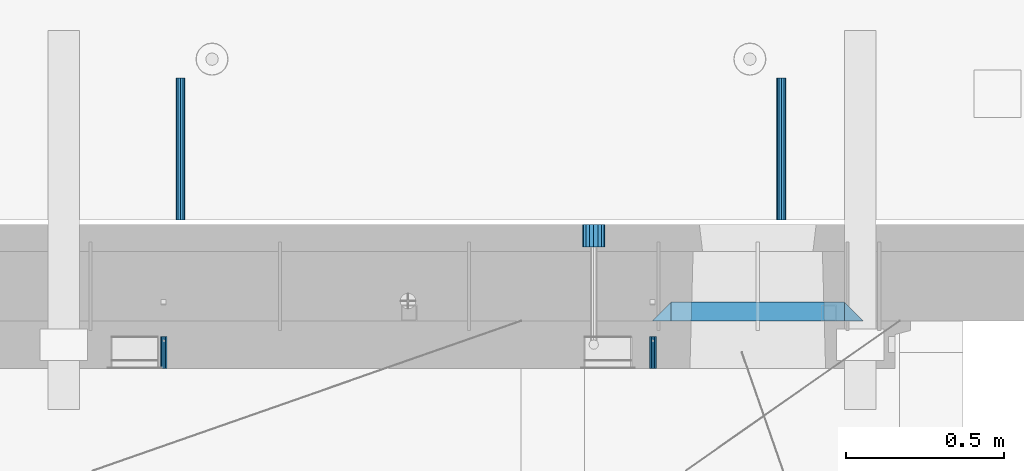
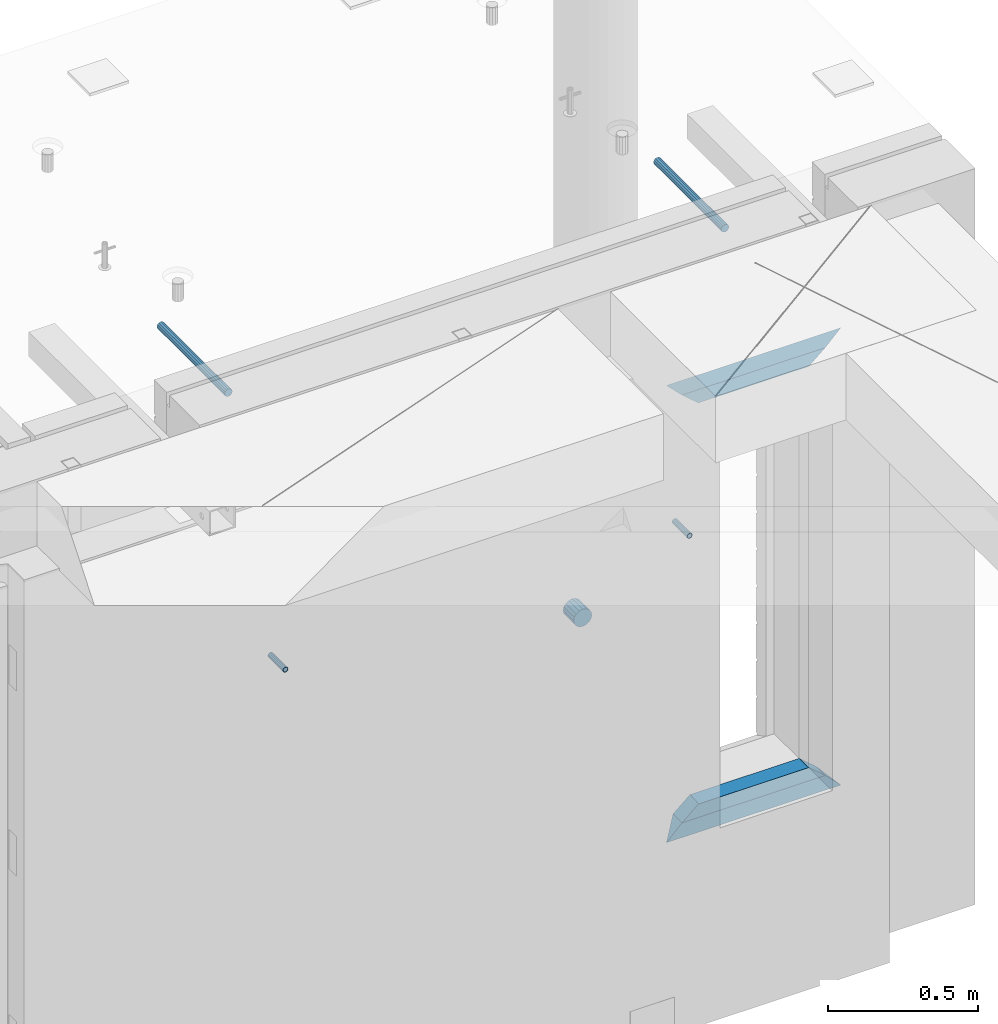
# One storey, part 143 of 309: 9 beams, 6 elements without a shape of their own.
"""IFC2X3 building model written with IfcOpenShell, lengths in millimetres."""

from ifc_helpers import new_model, si_unit, frame, origin_with_axes, place, context, subcontext, project, spatial, faceted_brep, material, type_object, element, aggregate, save


model = new_model("IFC2X3")

# Units and contexts
model_context = context("Model", 3, precision=1e-05, world=origin_with_axes())
body_context = subcontext(model_context, "Body", "Model", "MODEL_VIEW")
ifc_project = project(units=[si_unit("LENGTHUNIT", "METRE", prefix="MILLI"), si_unit("AREAUNIT", "SQUARE_METRE"), si_unit("VOLUMEUNIT", "CUBIC_METRE"), si_unit("MASSUNIT", "GRAM", prefix="KILO"), si_unit("TIMEUNIT", "SECOND"), si_unit("PLANEANGLEUNIT", "RADIAN"), si_unit("SOLIDANGLEUNIT", "STERADIAN"), si_unit("THERMODYNAMICTEMPERATUREUNIT", "DEGREE_CELSIUS"), si_unit("LUMINOUSINTENSITYUNIT", "LUMEN")], contexts=[model_context])

# Site, building, storey
site_placement = place(None, origin_with_axes())
site = spatial("IfcSite", under=ifc_project, at=site_placement, CompositionType="ELEMENT")
building_placement = place(site_placement, origin_with_axes())
building = spatial("IfcBuilding", under=site, at=building_placement, CompositionType="ELEMENT")
storey_placement = place(building_placement, origin_with_axes())
storey = spatial("IfcBuildingStorey", under=building, at=storey_placement, Name="7", CompositionType="ELEMENT", Elevation=0.0)

# Assemblies, beams
assembly_1_placement = place(storey_placement, origin_with_axes())
assembly_1 = element("IfcElementAssembly", 1, at=assembly_1_placement, inside=storey, AssemblyPlace="NOTDEFINED", PredefinedType="REINFORCEMENT_UNIT")
assembly_2_placement = place(assembly_1_placement, origin_with_axes())
assembly_2 = element("IfcElementAssembly", 2, at=assembly_2_placement, Name="Steel Assembly", AssemblyPlace="NOTDEFINED", PredefinedType="RIGID_FRAME")
ifc_material_1 = material(Name="STEEL/Steel_Undefined")
beam_type_1 = type_object("IfcBeamType", PredefinedType="NOTDEFINED")
beam_1_placement = place(assembly_2_placement, frame((34077.8782931989, 20429.9951872276, 101755.0), z_axis=(-1.0, 3.00000001838171e-08, 0.0), x_axis=(0.0, 1.0, 0.0)))
beam_1 = element("IfcBeam", 3, at=beam_1_placement, type_object=beam_type_1, material=ifc_material_1, Name="M16", context=body_context, shape_type="Brep", body=[
    faceted_brep([(0.0, -8.49999999999272, -1.45519152283669e-11), (0.0, -7.36121593215648, 4.24999999998545), (100.000000000262, -7.36121593215648, 4.24999999998545), (100.000000000262, -8.49999999999272, -1.45519152283669e-11), (0.0, -4.24999999998545, 7.36121593216376), (100.000000000262, -4.24999999998545, 7.36121593216376), (0.0, 1.45519152283669e-11, 8.49999999998545), (100.000000000262, 1.45519152283669e-11, 8.49999999998545), (0.0, 4.25000000001455, 7.36121593216376), (100.000000000262, 4.25000000001455, 7.36121593216376), (0.0, 7.36121593217104, 4.24999999998545), (100.000000000262, 7.36121593217104, 4.24999999998545), (0.0, 8.50000000000728, 0.0), (100.000000000262, 8.50000000000728, 0.0), (0.0, 7.36121593217104, -4.25000000001455), (100.000000000262, 7.36121593217104, -4.25000000001455), (0.0, 4.25000000000728, -7.36121593219286), (100.000000000262, 4.25000000000728, -7.36121593219286), (0.0, 7.27595761418343e-12, -8.5), (100.000000000262, 7.27595761418343e-12, -8.5), (0.0, -4.24999999999272, -7.36121593217831), (100.000000000262, -4.24999999999272, -7.36121593217831), (0.0, -7.36121593215648, -4.25), (100.000000000262, -7.36121593215648, -4.25), (0.0, -10.4999999999927, -1.45519152283669e-11), (0.0, -9.09326673972828, -5.25000000001455), (100.000000000262, -9.09326673972828, -5.25000000001455), (100.000000000262, -10.4999999999927, -1.45519152283669e-11), (0.0, -5.24999999998545, -9.09326673974283), (100.000000000262, -5.24999999998545, -9.09326673974283), (0.0, 7.27595761418343e-12, -10.5), (100.000000000262, 7.27595761418343e-12, -10.5), (0.0, 5.25000000001455, -9.09326673975738), (100.000000000262, 5.25000000001455, -9.09326673975738), (0.0, 9.09326673975011, -5.25000000001455), (100.000000000262, 9.09326673975011, -5.25000000001455), (0.0, 10.5000000000073, -1.45519152283669e-11), (100.000000000262, 10.5000000000073, -1.45519152283669e-11), (0.0, 9.09326673975011, 5.25), (100.000000000262, 9.09326673975011, 5.25), (0.0, 5.25000000000728, 9.09326673972828), (100.000000000262, 5.25000000000728, 9.09326673972828), (0.0, 1.45519152283669e-11, 10.4999999999854), (100.000000000262, 1.45519152283669e-11, 10.4999999999854), (0.0, -5.24999999999272, 9.09326673972828), (100.000000000262, -5.24999999999272, 9.09326673972828), (0.0, -9.09326673972828, 5.24999999998545), (100.000000000262, -9.09326673972828, 5.24999999998545)], [[[0, 1, 2, 3]], [[1, 4, 5, 2]], [[4, 6, 7, 5]], [[6, 8, 9, 7]], [[8, 10, 11, 9]], [[10, 12, 13, 11]], [[12, 14, 15, 13]], [[14, 16, 17, 15]], [[16, 18, 19, 17]], [[18, 20, 21, 19]], [[20, 22, 23, 21]], [[22, 0, 3, 23]], [[24, 25, 26, 27]], [[25, 28, 29, 26]], [[28, 30, 31, 29]], [[30, 32, 33, 31]], [[32, 34, 35, 33]], [[34, 36, 37, 35]], [[36, 38, 39, 37]], [[38, 40, 41, 39]], [[40, 42, 43, 41]], [[42, 44, 45, 43]], [[44, 46, 47, 45]], [[46, 24, 27, 47]], [[29, 31, 33, 35, 37, 39, 41, 43, 45, 47, 27, 26], [5, 7, 9, 11, 13, 15, 17, 19, 21, 23, 3, 2]], [[46, 44, 42, 40, 38, 36, 34, 32, 30, 28, 25, 24], [22, 20, 18, 16, 14, 12, 10, 8, 6, 4, 1, 0]]]),
])
aggregate(assembly_2, [beam_1])
assembly_3_placement = place(assembly_1_placement, origin_with_axes())
assembly_3 = element("IfcElementAssembly", 4, at=assembly_3_placement, Name="Steel Assembly", AssemblyPlace="NOTDEFINED", PredefinedType="RIGID_FRAME")
beam_2_placement = place(assembly_3_placement, frame((32527.3782931989, 20429.9951872276, 101755.0), z_axis=(-1.0, 3.00000001838171e-08, 0.0), x_axis=(0.0, 1.0, 0.0)))
beam_2 = element("IfcBeam", 5, at=beam_2_placement, type_object=beam_type_1, material=ifc_material_1, Name="M16", context=body_context, shape_type="Brep", body=[
    faceted_brep([(0.0, -8.49999999999272, -1.45519152283669e-11), (0.0, -7.36121593215648, 4.24999999998545), (100.000000000262, -7.36121593215648, 4.24999999998545), (100.000000000262, -8.49999999999272, -1.45519152283669e-11), (0.0, -4.24999999998545, 7.36121593216376), (100.000000000262, -4.24999999998545, 7.36121593216376), (0.0, 1.45519152283669e-11, 8.49999999998545), (100.000000000262, 1.45519152283669e-11, 8.49999999998545), (0.0, 4.25000000001455, 7.36121593216376), (100.000000000262, 4.25000000001455, 7.36121593216376), (0.0, 7.36121593217104, 4.24999999998545), (100.000000000262, 7.36121593217104, 4.24999999998545), (0.0, 8.50000000000728, 0.0), (100.000000000262, 8.50000000000728, 0.0), (0.0, 7.36121593217104, -4.25000000001455), (100.000000000262, 7.36121593217104, -4.25000000001455), (0.0, 4.25000000000728, -7.36121593219286), (100.000000000262, 4.25000000000728, -7.36121593219286), (0.0, 7.27595761418343e-12, -8.5), (100.000000000262, 7.27595761418343e-12, -8.5), (0.0, -4.24999999999272, -7.36121593217831), (100.000000000262, -4.24999999999272, -7.36121593217831), (0.0, -7.36121593215648, -4.25), (100.000000000262, -7.36121593215648, -4.25), (0.0, -10.4999999999927, -1.45519152283669e-11), (0.0, -9.09326673972828, -5.25000000001455), (100.000000000262, -9.09326673972828, -5.25000000001455), (100.000000000262, -10.4999999999927, -1.45519152283669e-11), (0.0, -5.24999999998545, -9.09326673974283), (100.000000000262, -5.24999999998545, -9.09326673974283), (0.0, 7.27595761418343e-12, -10.5), (100.000000000262, 7.27595761418343e-12, -10.5), (0.0, 5.25000000001455, -9.09326673975738), (100.000000000262, 5.25000000001455, -9.09326673975738), (0.0, 9.09326673975011, -5.25000000001455), (100.000000000262, 9.09326673975011, -5.25000000001455), (0.0, 10.5000000000073, -1.45519152283669e-11), (100.000000000262, 10.5000000000073, -1.45519152283669e-11), (0.0, 9.09326673975011, 5.25), (100.000000000262, 9.09326673975011, 5.25), (0.0, 5.25000000000728, 9.09326673972828), (100.000000000262, 5.25000000000728, 9.09326673972828), (0.0, 1.45519152283669e-11, 10.4999999999854), (100.000000000262, 1.45519152283669e-11, 10.4999999999854), (0.0, -5.24999999999272, 9.09326673972828), (100.000000000262, -5.24999999999272, 9.09326673972828), (0.0, -9.09326673972828, 5.24999999998545), (100.000000000262, -9.09326673972828, 5.24999999998545)], [[[0, 1, 2, 3]], [[1, 4, 5, 2]], [[4, 6, 7, 5]], [[6, 8, 9, 7]], [[8, 10, 11, 9]], [[10, 12, 13, 11]], [[12, 14, 15, 13]], [[14, 16, 17, 15]], [[16, 18, 19, 17]], [[18, 20, 21, 19]], [[20, 22, 23, 21]], [[22, 0, 3, 23]], [[24, 25, 26, 27]], [[25, 28, 29, 26]], [[28, 30, 31, 29]], [[30, 32, 33, 31]], [[32, 34, 35, 33]], [[34, 36, 37, 35]], [[36, 38, 39, 37]], [[38, 40, 41, 39]], [[40, 42, 43, 41]], [[42, 44, 45, 43]], [[44, 46, 47, 45]], [[46, 24, 27, 47]], [[29, 31, 33, 35, 37, 39, 41, 43, 45, 47, 27, 26], [5, 7, 9, 11, 13, 15, 17, 19, 21, 23, 3, 2]], [[46, 44, 42, 40, 38, 36, 34, 32, 30, 28, 25, 24], [22, 20, 18, 16, 14, 12, 10, 8, 6, 4, 1, 0]]]),
])
aggregate(assembly_3, [beam_2])
ifc_material_2 = material()
beam_type_2 = type_object("IfcBeamType", Name="D70", PredefinedType="NOTDEFINED")
beam_3_placement = place(assembly_1_placement, frame((33890.0, 20884.9951872276, 101255.0), z_axis=(0.0, 0.0, 1.0), x_axis=(0.0, -1.0, 0.0)))
beam_3 = element("IfcBeam", 6, at=beam_3_placement, type_object=beam_type_2, material=ifc_material_2, ObjectType="D70", context=body_context, shape_type="Brep", body=[
    faceted_brep([(0.0, -35.0, 0.0), (0.0, -32.3357836378964, -13.3939201327739), (70.0, -32.3357836378964, -13.3939201327739), (70.0, -35.0, 0.0), (0.0, -24.7487373415279, -24.7487373415352), (70.0, -24.7487373415279, -24.7487373415352), (0.0, -13.3939201327776, -32.3357836379), (70.0, -13.3939201327776, -32.3357836379), (0.0, 0.0, -35.0), (70.0, 0.0, -35.0), (0.0, 13.3939201327776, -32.3357836379), (70.0, 13.3939201327776, -32.3357836379), (0.0, 24.7487373415279, -24.7487373415352), (70.0, 24.7487373415279, -24.7487373415352), (0.0, 32.3357836378964, -13.3939201327739), (70.0, 32.3357836378964, -13.3939201327739), (0.0, 35.0, 0.0), (70.0, 35.0, 0.0), (0.0, 32.3357836378964, 13.3939201327739), (70.0, 32.3357836378964, 13.3939201327739), (0.0, 24.7487373415279, 24.7487373415352), (70.0, 24.7487373415279, 24.7487373415352), (0.0, 13.3939201327776, 32.3357836379), (70.0, 13.3939201327776, 32.3357836379), (0.0, 0.0, 35.0), (70.0, 0.0, 35.0), (0.0, -13.3939201327776, 32.3357836379), (70.0, -13.3939201327776, 32.3357836379), (0.0, -24.7487373415279, 24.7487373415352), (70.0, -24.7487373415279, 24.7487373415352), (0.0, -32.3357836378964, 13.3939201327739), (70.0, -32.3357836378964, 13.3939201327739)], [[[0, 1, 2, 3]], [[1, 4, 5, 2]], [[4, 6, 7, 5]], [[6, 8, 9, 7]], [[8, 10, 11, 9]], [[10, 12, 13, 11]], [[12, 14, 15, 13]], [[14, 16, 17, 15]], [[16, 18, 19, 17]], [[18, 20, 21, 19]], [[20, 22, 23, 21]], [[22, 24, 25, 23]], [[24, 26, 27, 25]], [[26, 28, 29, 27]], [[28, 30, 31, 29]], [[30, 0, 3, 31]], [[5, 7, 9, 11, 13, 15, 17, 19, 21, 23, 25, 27, 29, 31, 3, 2]], [[30, 28, 26, 24, 22, 20, 18, 16, 14, 12, 10, 8, 6, 4, 1, 0]]]),
])

assembly_4_placement = place(storey_placement, origin_with_axes())
assembly_4 = element("IfcElementAssembly", 7, at=assembly_4_placement, inside=storey, AssemblyPlace="NOTDEFINED", PredefinedType="REINFORCEMENT_UNIT")
assembly_5_placement = place(assembly_4_placement, origin_with_axes())
assembly_5 = element("IfcElementAssembly", 8, at=assembly_5_placement, Name="Steel Assembly", AssemblyPlace="NOTDEFINED", PredefinedType="RIGID_FRAME")
ifc_material_3 = material(Name="STEEL/S235JR")
beam_type_3 = type_object("IfcBeamType", Name="D30", PredefinedType="NOTDEFINED")
beam_4_placement = place(assembly_5_placement, frame((32579.9998567563, 20900.0253394533, 102575.0), z_axis=(0.0, 0.0, 1.0), x_axis=(0.0, 1.0, 0.0)))
beam_4 = element("IfcBeam", 9, at=beam_4_placement, type_object=beam_type_3, material=ifc_material_3, Name="Rd30", ObjectType="D30", context=body_context, shape_type="Brep", body=[
    faceted_brep([(0.0, -15.0, 0.0), (0.0, -12.9903810567666, -7.5), (450.0, -12.9903810567666, -7.5), (450.0, -15.0, 0.0), (0.0, -7.5, -12.9903810567666), (450.0, -7.5, -12.990381056763), (0.0, 0.0, -15.0), (450.0, 0.0, -15.0), (0.0, 7.5, -12.9903810567666), (450.0, 7.5, -12.990381056763), (0.0, 12.9903810567666, -7.5), (450.0, 12.9903810567666, -7.5), (0.0, 15.0, 0.0), (450.0, 15.0, 0.0), (0.0, 12.9903810567666, 7.5), (450.0, 12.9903810567666, 7.5), (0.0, 7.5, 12.9903810567666), (450.0, 7.5, 12.990381056763), (0.0, 0.0, 15.0), (450.0, 0.0, 15.0), (0.0, -7.5, 12.9903810567666), (450.0, -7.5, 12.990381056763), (0.0, -12.9903810567666, 7.5), (450.0, -12.9903810567666, 7.5)], [[[0, 1, 2, 3]], [[1, 4, 5, 2]], [[4, 6, 7, 5]], [[6, 8, 9, 7]], [[8, 10, 11, 9]], [[10, 12, 13, 11]], [[12, 14, 15, 13]], [[14, 16, 17, 15]], [[16, 18, 19, 17]], [[18, 20, 21, 19]], [[20, 22, 23, 21]], [[22, 0, 3, 23]], [[5, 7, 9, 11, 13, 15, 17, 19, 21, 23, 3, 2]], [[22, 20, 18, 16, 14, 12, 10, 8, 6, 4, 1, 0]]]),
])
aggregate(assembly_5, [beam_4])
assembly_6_placement = place(assembly_4_placement, origin_with_axes())
assembly_6 = element("IfcElementAssembly", 10, at=assembly_6_placement, Name="Steel Assembly", AssemblyPlace="NOTDEFINED", PredefinedType="RIGID_FRAME")
aggregate(assembly_4, [assembly_5, assembly_6])
beam_5_placement = place(assembly_6_placement, frame((34484.9998570066, 20900.0152136098, 102575.0), z_axis=(0.0, 0.0, 1.0), x_axis=(0.0, 1.0, 0.0)))
beam_5 = element("IfcBeam", 11, at=beam_5_placement, type_object=beam_type_3, material=ifc_material_3, Name="Rd30", ObjectType="D30", context=body_context, shape_type="Brep", body=[
    faceted_brep([(0.0, -15.0, 0.0), (0.0, -12.9903810567666, -7.5), (450.0, -12.9903810567666, -7.5), (450.0, -15.0, 0.0), (0.0, -7.5, -12.9903810567666), (450.0, -7.5, -12.990381056763), (0.0, 0.0, -15.0), (450.0, 0.0, -15.0), (0.0, 7.5, -12.9903810567666), (450.0, 7.5, -12.990381056763), (0.0, 12.9903810567666, -7.5), (450.0, 12.9903810567666, -7.5), (0.0, 15.0, 0.0), (450.0, 15.0, 0.0), (0.0, 12.9903810567666, 7.5), (450.0, 12.9903810567666, 7.5), (0.0, 7.5, 12.9903810567666), (450.0, 7.5, 12.990381056763), (0.0, 0.0, 15.0), (450.0, 0.0, 15.0), (0.0, -7.5, 12.9903810567666), (450.0, -7.5, 12.990381056763), (0.0, -12.9903810567666, 7.5), (450.0, -12.9903810567666, 7.5)], [[[0, 1, 2, 3]], [[1, 4, 5, 2]], [[4, 6, 7, 5]], [[6, 8, 9, 7]], [[8, 10, 11, 9]], [[10, 12, 13, 11]], [[12, 14, 15, 13]], [[14, 16, 17, 15]], [[16, 18, 19, 17]], [[18, 20, 21, 19]], [[20, 22, 23, 21]], [[22, 0, 3, 23]], [[5, 7, 9, 11, 13, 15, 17, 19, 21, 23, 3, 2]], [[22, 20, 18, 16, 14, 12, 10, 8, 6, 4, 1, 0]]]),
])
aggregate(assembly_6, [beam_5])

# Beam
ifc_material_4 = material(Name="CONCRETE/C25/30")
beam_type_4 = type_object("IfcBeamType", PredefinedType="NOTDEFINED")
beam_6_placement = place(assembly_1_placement, frame((34684.9994055559, 20609.9951872276, 102185.0), z_axis=(0.0, 0.0, -1.0), x_axis=(-1.0, 3.00000001838171e-08, 0.0)))
beam_6 = element("IfcBeam", 12, at=beam_6_placement, type_object=beam_type_4, material=ifc_material_4, Name="SK", context=body_context, shape_type="Brep", body=[
    faceted_brep([(64.057950538423, -30.0, 24.9068147351645), (65.6795721600429, 30.0, 26.2967761248292), (0.0, 30.0, -30.0), (0.0, -30.0, -30.0), (64.057950538423, -30.0, 24.0540540540533), (65.6795721600429, 30.0, 25.6756756756804), (485.939842430322, -30.0, 24.0540540540533), (484.318220808702, 30.0, 25.6756756756804), (484.318220808702, 30.0, 26.293436281092), (549.993896484375, 30.0, -30.0), (549.993896484375, -30.0, -30.0), (485.939842430322, -30.0, 24.9034748914273)], [[[0, 1, 2, 3]], [[4, 5, 1, 0]], [[6, 7, 5, 4]], [[2, 1, 5, 7, 8, 9]], [[3, 2, 9, 10]], [[6, 4, 0, 3, 10, 11]], [[7, 6, 11, 8]], [[10, 9, 8, 11]]]),
])

beam_7_placement = place(assembly_1_placement, frame((34744.9994055559, 20609.9951872276, 102245.0), z_axis=(0.0, 0.0, -1.0), x_axis=(-1.0, 3.00000001838171e-08, 0.0)))
beam_7 = element("IfcBeam", 13, at=beam_7_placement, type_object=beam_type_4, material=ifc_material_4, Name="SK", context=body_context, shape_type="Brep", body=[
    faceted_brep([(60.0000000000073, 30.0, 30.0), (0.0, -30.0, -30.0), (60.0000000000073, -30.0, 30.0), (609.993896484397, 30.0, 30.0), (669.993896484375, -30.0, -30.0), (609.993896484397, -30.0, 30.0)], [[[0, 1, 2]], [[1, 0, 3, 4]], [[2, 1, 4, 5]], [[0, 2, 5, 3]], [[4, 3, 5]]]),
])

beam_8_placement = place(assembly_1_placement, frame((34075.0055090716, 20609.9951872276, 100450.0), z_axis=(0.0, 0.0, 1.0), x_axis=(1.0, 0.0, 0.0)))
beam_8 = element("IfcBeam", 14, at=beam_8_placement, type_object=beam_type_4, material=ifc_material_4, Name="SK", context=body_context, shape_type="Brep", body=[
    faceted_brep([(669.993896484375, -30.0, -30.0), (609.993896484397, 30.0, 30.0), (609.993896484397, -30.0, 30.0), (60.0000000000073, 30.0, 30.0), (60.0000000000073, -30.0, 30.0), (0.0, -30.0, -30.0)], [[[0, 1, 2]], [[3, 4, 2, 1]], [[4, 5, 0, 2]], [[5, 3, 1, 0]], [[3, 5, 4]]]),
])

beam_9_placement = place(assembly_1_placement, frame((34135.0055090716, 20609.9951872276, 100510.0), z_axis=(0.0, 0.0, 1.0), x_axis=(1.0, 0.0, 0.0)))
beam_9 = element("IfcBeam", 15, at=beam_9_placement, type_object=beam_type_4, material=ifc_material_4, Name="SK", context=body_context, shape_type="Brep", body=[
    faceted_brep([(485.935945945952, -30.0, 24.9068147351645), (549.993896484375, -30.0, -30.0), (549.993896484375, 30.0, -30.0), (484.314324324332, 30.0, 26.2967761248292), (484.314324324332, 30.0, 25.6756756756804), (485.935945945952, -30.0, 24.0540540540533), (65.6756756756768, 30.0, 25.6756756756804), (64.0540540540533, -30.0, 24.0540540540533), (65.6756756756768, 30.0, 26.293436281092), (64.0540540540533, -30.0, 24.9034748914419), (0.0, -30.0, -30.0), (0.0, 30.0, -30.0)], [[[0, 1, 2, 3]], [[4, 5, 0, 3]], [[5, 4, 6, 7]], [[7, 6, 8, 9]], [[1, 0, 5, 7, 9, 10]], [[10, 11, 2, 1]], [[6, 4, 3, 2, 11, 8]], [[10, 9, 8, 11]]]),
])

aggregate(assembly_1, [beam_3, assembly_2, beam_6, beam_7, beam_8, beam_9, assembly_3])

save(model, "model.ifc")
